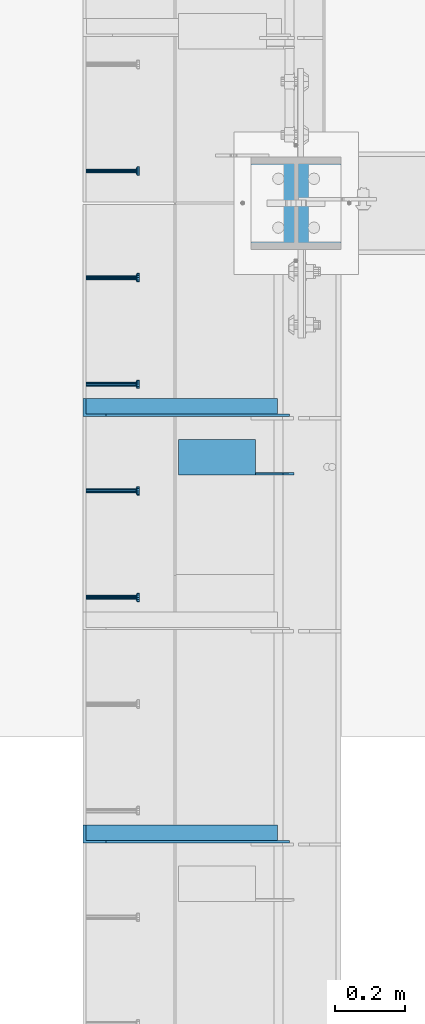
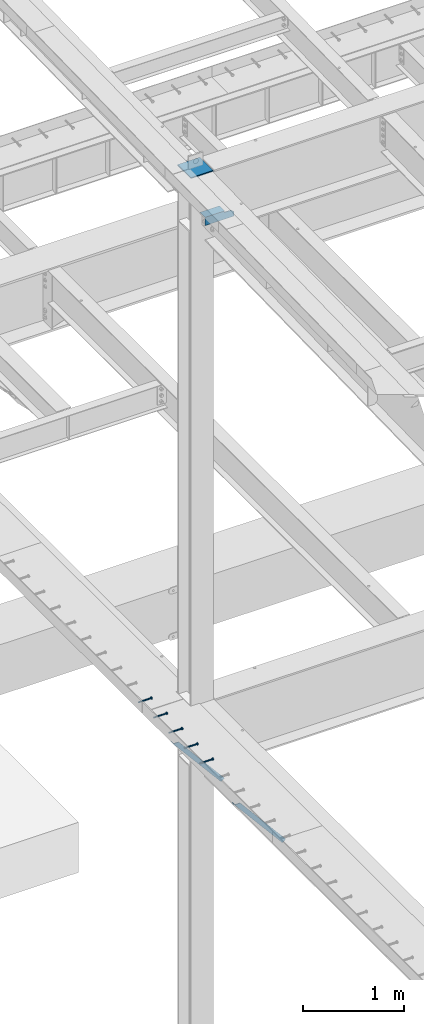
# One storey, part 1280 of 1763: 7 beams, 2 members, 8 elements without a shape of their own.
"""IFC2X3 building model written with IfcOpenShell, lengths in millimetres."""

from ifc_helpers import new_model, si_unit, frame, origin_with_axes, place, context, subcontext, project, spatial, faceted_brep, material, type_object, element, aggregate, save


model = new_model("IFC2X3")

# Units and contexts
model_context = context("Model", 3, precision=1e-05, world=origin_with_axes())
body_context = subcontext(model_context, "Body", "Model", "MODEL_VIEW")
ifc_project = project(units=[si_unit("LENGTHUNIT", "METRE", prefix="MILLI"), si_unit("AREAUNIT", "SQUARE_METRE"), si_unit("VOLUMEUNIT", "CUBIC_METRE"), si_unit("MASSUNIT", "GRAM", prefix="KILO"), si_unit("TIMEUNIT", "SECOND"), si_unit("PLANEANGLEUNIT", "RADIAN"), si_unit("SOLIDANGLEUNIT", "STERADIAN"), si_unit("THERMODYNAMICTEMPERATUREUNIT", "DEGREE_CELSIUS"), si_unit("LUMINOUSINTENSITYUNIT", "LUMEN")], contexts=[model_context])

# Site, building, storey
site_placement = place(None, origin_with_axes())
site = spatial("IfcSite", under=ifc_project, at=site_placement, CompositionType="ELEMENT")
building_placement = place(site_placement, origin_with_axes())
building = spatial("IfcBuilding", under=site, at=building_placement, Name="Undefined", CompositionType="ELEMENT")
storey_placement = place(building_placement, origin_with_axes())
storey = spatial("IfcBuildingStorey", under=building, at=storey_placement, Name="Undefined", CompositionType="ELEMENT", Elevation=0.0)

# Assembly, beam
assembly_1_placement = place(storey_placement, origin_with_axes())
assembly_1 = element("IfcElementAssembly", 1, at=assembly_1_placement, inside=storey, Name="HEADED STUD ANCHOR", AssemblyPlace="NOTDEFINED", PredefinedType="RIGID_FRAME")
ifc_material_1 = material(Name="STEEL/A108")
beam_type_1 = type_object("IfcBeamType", PredefinedType="NOTDEFINED")
beam_1_placement = place(assembly_1_placement, frame((-87975.5122736983, 43678.4750061035, 5268.91250001202), z_axis=(0.0, 0.0, -1.0), x_axis=(1.0, 0.0, 0.0)))
beam_1 = element("IfcBeam", 2, at=beam_1_placement, type_object=beam_type_1, material=ifc_material_1, Name="HEADED STUD ANCHOR", context=body_context, shape_type="Brep", body=[
    faceted_brep([(0.0, -3.1800000667572, 5.5), (0.0, -5.5, 3.1800000667572), (141.732000000002, -5.5, 3.1800000667572), (141.732000000002, -3.1800000667572, 5.5), (0.0, -6.34999999999491, 1.45519152283669e-11), (141.732000000002, -6.34999990463257, 0.0), (0.0, -5.5, -3.1800000667572), (141.732000000002, -5.5, -3.1800000667572), (0.0, -3.1800000667572, -5.5), (141.732000000002, -3.1800000667572, -5.5), (0.0, 0.0, -6.34999990463257), (141.732000000002, 0.0, -6.34999990463257), (0.0, 3.1800000667572, -5.5), (141.732000000002, 3.1800000667572, -5.5), (0.0, 5.5, -3.1800000667572), (141.732000000002, 5.5, -3.1800000667572), (0.0, 6.34999999999491, -2.91038304567337e-11), (141.732000000002, 6.34999990463257, 0.0), (0.0, 5.5, 3.1800000667572), (141.732000000002, 5.5, 3.1800000667572), (0.0, 3.1800000667572, 5.5), (141.732000000002, 3.1800000667572, 5.5), (0.0, 0.0, 6.34999990463257), (141.732000000002, 0.0, 6.34999990463257), (144.780000000001, -10.9899997711182, 6.34999990463257), (144.780000000001, -6.34000015258789, 10.9899997711182), (144.780000000001, -12.6999998092651, 0.0), (144.780000000001, -10.9899997711182, -6.34999990463257), (144.780000000001, -6.34000015258789, -10.9899997711182), (144.780000000001, 0.0, -12.6899995803833), (144.780000000001, 6.34000015258789, -10.9899997711182), (144.780000000001, 10.9899997711182, -6.34999990463257), (144.780000000001, 12.6999998092651, 0.0), (144.780000000001, 10.9899997711182, 6.34999990463257), (144.780000000001, 6.34000015258789, 10.9899997711182), (144.780000000001, 0.0, 12.6899995803833), (152.400000000001, -10.9899997711182, 6.34999990463257), (152.400000000001, -6.34000015258789, 10.9899997711182), (152.400000000001, -12.6999998092651, 0.0), (152.400000000001, -10.9899997711182, -6.34999990463257), (152.400000000001, -6.34000015258789, -10.9899997711182), (152.400000000001, 0.0, -12.6899995803833), (152.400000000001, 6.34000015258789, -10.9899997711182), (152.400000000001, 10.9899997711182, -6.34999990463257), (152.400000000001, 12.6999998092651, 0.0), (152.400000000001, 10.9899997711182, 6.34999990463257), (152.400000000001, 6.34000015258789, 10.9899997711182), (152.400000000001, 0.0, 12.6899995803833)], [[[0, 1, 2, 3]], [[1, 4, 5, 2]], [[4, 6, 7, 5]], [[6, 8, 9, 7]], [[8, 10, 11, 9]], [[10, 12, 13, 11]], [[12, 14, 15, 13]], [[14, 16, 17, 15]], [[16, 18, 19, 17]], [[18, 20, 21, 19]], [[20, 22, 23, 21]], [[22, 0, 3, 23]], [[22, 20, 18, 16, 14, 12, 10, 8, 6, 4, 1, 0]], [[3, 2, 24, 25]], [[2, 5, 26, 24]], [[5, 7, 27, 26]], [[7, 9, 28, 27]], [[9, 11, 29, 28]], [[11, 13, 30, 29]], [[13, 15, 31, 30]], [[15, 17, 32, 31]], [[17, 19, 33, 32]], [[19, 21, 34, 33]], [[21, 23, 35, 34]], [[23, 3, 25, 35]], [[25, 24, 36, 37]], [[24, 26, 38, 36]], [[26, 27, 39, 38]], [[27, 28, 40, 39]], [[28, 29, 41, 40]], [[29, 30, 42, 41]], [[30, 31, 43, 42]], [[31, 32, 44, 43]], [[32, 33, 45, 44]], [[33, 34, 46, 45]], [[34, 35, 47, 46]], [[35, 25, 37, 47]], [[38, 39, 40, 41, 42, 43, 44, 45, 46, 47, 37, 36]]]),
])
aggregate(assembly_1, [beam_1])

assembly_2_placement = place(storey_placement, origin_with_axes())
assembly_2 = element("IfcElementAssembly", 3, at=assembly_2_placement, inside=storey, Name="HEADED STUD ANCHOR", AssemblyPlace="NOTDEFINED", PredefinedType="RIGID_FRAME")
beam_2_placement = place(assembly_2_placement, frame((-87975.5122736983, 43983.2750061035, 5268.91250001202), z_axis=(0.0, 0.0, -1.0), x_axis=(1.0, 0.0, 0.0)))
beam_2 = element("IfcBeam", 4, at=beam_2_placement, type_object=beam_type_1, material=ifc_material_1, Name="HEADED STUD ANCHOR", context=body_context, shape_type="Brep", body=[
    faceted_brep([(0.0, -3.1800000667572, 5.5), (0.0, -5.5, 3.1800000667572), (141.732000000002, -5.5, 3.1800000667572), (141.732000000002, -3.1800000667572, 5.5), (0.0, -6.34999999999491, 1.45519152283669e-11), (141.732000000002, -6.34999990463257, 0.0), (0.0, -5.5, -3.1800000667572), (141.732000000002, -5.5, -3.1800000667572), (0.0, -3.1800000667572, -5.5), (141.732000000002, -3.1800000667572, -5.5), (0.0, 0.0, -6.34999990463257), (141.732000000002, 0.0, -6.34999990463257), (0.0, 3.1800000667572, -5.5), (141.732000000002, 3.1800000667572, -5.5), (0.0, 5.5, -3.1800000667572), (141.732000000002, 5.5, -3.1800000667572), (0.0, 6.34999999999491, -2.91038304567337e-11), (141.732000000002, 6.34999990463257, 0.0), (0.0, 5.5, 3.1800000667572), (141.732000000002, 5.5, 3.1800000667572), (0.0, 3.1800000667572, 5.5), (141.732000000002, 3.1800000667572, 5.5), (0.0, 0.0, 6.34999990463257), (141.732000000002, 0.0, 6.34999990463257), (144.780000000001, -10.9899997711182, 6.34999990463257), (144.780000000001, -6.34000015258789, 10.9899997711182), (144.780000000001, -12.6999998092651, 0.0), (144.780000000001, -10.9899997711182, -6.34999990463257), (144.780000000001, -6.34000015258789, -10.9899997711182), (144.780000000001, 0.0, -12.6899995803833), (144.780000000001, 6.34000015258789, -10.9899997711182), (144.780000000001, 10.9899997711182, -6.34999990463257), (144.780000000001, 12.6999998092651, 0.0), (144.780000000001, 10.9899997711182, 6.34999990463257), (144.780000000001, 6.34000015258789, 10.9899997711182), (144.780000000001, 0.0, 12.6899995803833), (152.400000000001, -10.9899997711182, 6.34999990463257), (152.400000000001, -6.34000015258789, 10.9899997711182), (152.400000000001, -12.6999998092651, 0.0), (152.400000000001, -10.9899997711182, -6.34999990463257), (152.400000000001, -6.34000015258789, -10.9899997711182), (152.400000000001, 0.0, -12.6899995803833), (152.400000000001, 6.34000015258789, -10.9899997711182), (152.400000000001, 10.9899997711182, -6.34999990463257), (152.400000000001, 12.6999998092651, 0.0), (152.400000000001, 10.9899997711182, 6.34999990463257), (152.400000000001, 6.34000015258789, 10.9899997711182), (152.400000000001, 0.0, 12.6899995803833)], [[[0, 1, 2, 3]], [[1, 4, 5, 2]], [[4, 6, 7, 5]], [[6, 8, 9, 7]], [[8, 10, 11, 9]], [[10, 12, 13, 11]], [[12, 14, 15, 13]], [[14, 16, 17, 15]], [[16, 18, 19, 17]], [[18, 20, 21, 19]], [[20, 22, 23, 21]], [[22, 0, 3, 23]], [[22, 20, 18, 16, 14, 12, 10, 8, 6, 4, 1, 0]], [[3, 2, 24, 25]], [[2, 5, 26, 24]], [[5, 7, 27, 26]], [[7, 9, 28, 27]], [[9, 11, 29, 28]], [[11, 13, 30, 29]], [[13, 15, 31, 30]], [[15, 17, 32, 31]], [[17, 19, 33, 32]], [[19, 21, 34, 33]], [[21, 23, 35, 34]], [[23, 3, 25, 35]], [[25, 24, 36, 37]], [[24, 26, 38, 36]], [[26, 27, 39, 38]], [[27, 28, 40, 39]], [[28, 29, 41, 40]], [[29, 30, 42, 41]], [[30, 31, 43, 42]], [[31, 32, 44, 43]], [[32, 33, 45, 44]], [[33, 34, 46, 45]], [[34, 35, 47, 46]], [[35, 25, 37, 47]], [[38, 39, 40, 41, 42, 43, 44, 45, 46, 47, 37, 36]]]),
])
aggregate(assembly_2, [beam_2])

assembly_3_placement = place(storey_placement, origin_with_axes())
assembly_3 = element("IfcElementAssembly", 5, at=assembly_3_placement, inside=storey, Name="HEADED STUD ANCHOR", AssemblyPlace="NOTDEFINED", PredefinedType="RIGID_FRAME")
beam_3_placement = place(assembly_3_placement, frame((-87975.5122736983, 44288.0750061035, 5268.91250001202), z_axis=(0.0, 0.0, -1.0), x_axis=(1.0, 0.0, 0.0)))
beam_3 = element("IfcBeam", 6, at=beam_3_placement, type_object=beam_type_1, material=ifc_material_1, Name="HEADED STUD ANCHOR", context=body_context, shape_type="Brep", body=[
    faceted_brep([(0.0, -3.1800000667572, 5.5), (0.0, -5.5, 3.1800000667572), (141.732000000002, -5.5, 3.1800000667572), (141.732000000002, -3.1800000667572, 5.5), (0.0, -6.34999999999491, 1.45519152283669e-11), (141.732000000002, -6.34999990463257, 0.0), (0.0, -5.5, -3.1800000667572), (141.732000000002, -5.5, -3.1800000667572), (0.0, -3.1800000667572, -5.5), (141.732000000002, -3.1800000667572, -5.5), (0.0, 0.0, -6.34999990463257), (141.732000000002, 0.0, -6.34999990463257), (0.0, 3.1800000667572, -5.5), (141.732000000002, 3.1800000667572, -5.5), (0.0, 5.5, -3.1800000667572), (141.732000000002, 5.5, -3.1800000667572), (0.0, 6.34999999999491, -2.91038304567337e-11), (141.732000000002, 6.34999990463257, 0.0), (0.0, 5.5, 3.1800000667572), (141.732000000002, 5.5, 3.1800000667572), (0.0, 3.1800000667572, 5.5), (141.732000000002, 3.1800000667572, 5.5), (0.0, 0.0, 6.34999990463257), (141.732000000002, 0.0, 6.34999990463257), (144.780000000001, -10.9899997711182, 6.34999990463257), (144.780000000001, -6.34000015258789, 10.9899997711182), (144.780000000001, -12.6999998092651, 0.0), (144.780000000001, -10.9899997711182, -6.34999990463257), (144.780000000001, -6.34000015258789, -10.9899997711182), (144.780000000001, 0.0, -12.6899995803833), (144.780000000001, 6.34000015258789, -10.9899997711182), (144.780000000001, 10.9899997711182, -6.34999990463257), (144.780000000001, 12.6999998092651, 0.0), (144.780000000001, 10.9899997711182, 6.34999990463257), (144.780000000001, 6.34000015258789, 10.9899997711182), (144.780000000001, 0.0, 12.6899995803833), (152.400000000001, -10.9899997711182, 6.34999990463257), (152.400000000001, -6.34000015258789, 10.9899997711182), (152.400000000001, -12.6999998092651, 0.0), (152.400000000001, -10.9899997711182, -6.34999990463257), (152.400000000001, -6.34000015258789, -10.9899997711182), (152.400000000001, 0.0, -12.6899995803833), (152.400000000001, 6.34000015258789, -10.9899997711182), (152.400000000001, 10.9899997711182, -6.34999990463257), (152.400000000001, 12.6999998092651, 0.0), (152.400000000001, 10.9899997711182, 6.34999990463257), (152.400000000001, 6.34000015258789, 10.9899997711182), (152.400000000001, 0.0, 12.6899995803833)], [[[0, 1, 2, 3]], [[1, 4, 5, 2]], [[4, 6, 7, 5]], [[6, 8, 9, 7]], [[8, 10, 11, 9]], [[10, 12, 13, 11]], [[12, 14, 15, 13]], [[14, 16, 17, 15]], [[16, 18, 19, 17]], [[18, 20, 21, 19]], [[20, 22, 23, 21]], [[22, 0, 3, 23]], [[22, 20, 18, 16, 14, 12, 10, 8, 6, 4, 1, 0]], [[3, 2, 24, 25]], [[2, 5, 26, 24]], [[5, 7, 27, 26]], [[7, 9, 28, 27]], [[9, 11, 29, 28]], [[11, 13, 30, 29]], [[13, 15, 31, 30]], [[15, 17, 32, 31]], [[17, 19, 33, 32]], [[19, 21, 34, 33]], [[21, 23, 35, 34]], [[23, 3, 25, 35]], [[25, 24, 36, 37]], [[24, 26, 38, 36]], [[26, 27, 39, 38]], [[27, 28, 40, 39]], [[28, 29, 41, 40]], [[29, 30, 42, 41]], [[30, 31, 43, 42]], [[31, 32, 44, 43]], [[32, 33, 45, 44]], [[33, 34, 46, 45]], [[34, 35, 47, 46]], [[35, 25, 37, 47]], [[38, 39, 40, 41, 42, 43, 44, 45, 46, 47, 37, 36]]]),
])
aggregate(assembly_3, [beam_3])

assembly_4_placement = place(storey_placement, origin_with_axes())
assembly_4 = element("IfcElementAssembly", 7, at=assembly_4_placement, inside=storey, Name="HEADED STUD ANCHOR", AssemblyPlace="NOTDEFINED", PredefinedType="RIGID_FRAME")
beam_4_placement = place(assembly_4_placement, frame((-87975.5122736983, 44592.8750061035, 5268.91250001202), z_axis=(0.0, 0.0, -1.0), x_axis=(1.0, 0.0, 0.0)))
beam_4 = element("IfcBeam", 8, at=beam_4_placement, type_object=beam_type_1, material=ifc_material_1, Name="HEADED STUD ANCHOR", context=body_context, shape_type="Brep", body=[
    faceted_brep([(0.0, -3.1800000667572, 5.5), (0.0, -5.5, 3.1800000667572), (141.732000000002, -5.5, 3.1800000667572), (141.732000000002, -3.1800000667572, 5.5), (0.0, -6.34999999999491, 1.45519152283669e-11), (141.732000000002, -6.34999990463257, 0.0), (0.0, -5.5, -3.1800000667572), (141.732000000002, -5.5, -3.1800000667572), (0.0, -3.1800000667572, -5.5), (141.732000000002, -3.1800000667572, -5.5), (0.0, 0.0, -6.34999990463257), (141.732000000002, 0.0, -6.34999990463257), (0.0, 3.1800000667572, -5.5), (141.732000000002, 3.1800000667572, -5.5), (0.0, 5.5, -3.1800000667572), (141.732000000002, 5.5, -3.1800000667572), (0.0, 6.34999999999491, -2.91038304567337e-11), (141.732000000002, 6.34999990463257, 0.0), (0.0, 5.5, 3.1800000667572), (141.732000000002, 5.5, 3.1800000667572), (0.0, 3.1800000667572, 5.5), (141.732000000002, 3.1800000667572, 5.5), (0.0, 0.0, 6.34999990463257), (141.732000000002, 0.0, 6.34999990463257), (144.780000000001, -10.9899997711182, 6.34999990463257), (144.780000000001, -6.34000015258789, 10.9899997711182), (144.780000000001, -12.6999998092651, 0.0), (144.780000000001, -10.9899997711182, -6.34999990463257), (144.780000000001, -6.34000015258789, -10.9899997711182), (144.780000000001, 0.0, -12.6899995803833), (144.780000000001, 6.34000015258789, -10.9899997711182), (144.780000000001, 10.9899997711182, -6.34999990463257), (144.780000000001, 12.6999998092651, 0.0), (144.780000000001, 10.9899997711182, 6.34999990463257), (144.780000000001, 6.34000015258789, 10.9899997711182), (144.780000000001, 0.0, 12.6899995803833), (152.400000000001, -10.9899997711182, 6.34999990463257), (152.400000000001, -6.34000015258789, 10.9899997711182), (152.400000000001, -12.6999998092651, 0.0), (152.400000000001, -10.9899997711182, -6.34999990463257), (152.400000000001, -6.34000015258789, -10.9899997711182), (152.400000000001, 0.0, -12.6899995803833), (152.400000000001, 6.34000015258789, -10.9899997711182), (152.400000000001, 10.9899997711182, -6.34999990463257), (152.400000000001, 12.6999998092651, 0.0), (152.400000000001, 10.9899997711182, 6.34999990463257), (152.400000000001, 6.34000015258789, 10.9899997711182), (152.400000000001, 0.0, 12.6899995803833)], [[[0, 1, 2, 3]], [[1, 4, 5, 2]], [[4, 6, 7, 5]], [[6, 8, 9, 7]], [[8, 10, 11, 9]], [[10, 12, 13, 11]], [[12, 14, 15, 13]], [[14, 16, 17, 15]], [[16, 18, 19, 17]], [[18, 20, 21, 19]], [[20, 22, 23, 21]], [[22, 0, 3, 23]], [[22, 20, 18, 16, 14, 12, 10, 8, 6, 4, 1, 0]], [[3, 2, 24, 25]], [[2, 5, 26, 24]], [[5, 7, 27, 26]], [[7, 9, 28, 27]], [[9, 11, 29, 28]], [[11, 13, 30, 29]], [[13, 15, 31, 30]], [[15, 17, 32, 31]], [[17, 19, 33, 32]], [[19, 21, 34, 33]], [[21, 23, 35, 34]], [[23, 3, 25, 35]], [[25, 24, 36, 37]], [[24, 26, 38, 36]], [[26, 27, 39, 38]], [[27, 28, 40, 39]], [[28, 29, 41, 40]], [[29, 30, 42, 41]], [[30, 31, 43, 42]], [[31, 32, 44, 43]], [[32, 33, 45, 44]], [[33, 34, 46, 45]], [[34, 35, 47, 46]], [[35, 25, 37, 47]], [[38, 39, 40, 41, 42, 43, 44, 45, 46, 47, 37, 36]]]),
])
aggregate(assembly_4, [beam_4])

assembly_5_placement = place(storey_placement, origin_with_axes())
assembly_5 = element("IfcElementAssembly", 9, at=assembly_5_placement, inside=storey, Name="HEADED STUD ANCHOR", AssemblyPlace="NOTDEFINED", PredefinedType="RIGID_FRAME")
beam_5_placement = place(assembly_5_placement, frame((-87975.5122736983, 44897.6750061035, 5268.91250001202), z_axis=(0.0, 0.0, -1.0), x_axis=(1.0, 0.0, 0.0)))
beam_5 = element("IfcBeam", 10, at=beam_5_placement, type_object=beam_type_1, material=ifc_material_1, Name="HEADED STUD ANCHOR", context=body_context, shape_type="Brep", body=[
    faceted_brep([(0.0, -3.1800000667572, 5.5), (0.0, -5.5, 3.1800000667572), (141.732000000002, -5.5, 3.1800000667572), (141.732000000002, -3.1800000667572, 5.5), (0.0, -6.34999999999491, 1.45519152283669e-11), (141.732000000002, -6.34999990463257, 0.0), (0.0, -5.5, -3.1800000667572), (141.732000000002, -5.5, -3.1800000667572), (0.0, -3.1800000667572, -5.5), (141.732000000002, -3.1800000667572, -5.5), (0.0, 0.0, -6.34999990463257), (141.732000000002, 0.0, -6.34999990463257), (0.0, 3.1800000667572, -5.5), (141.732000000002, 3.1800000667572, -5.5), (0.0, 5.5, -3.1800000667572), (141.732000000002, 5.5, -3.1800000667572), (0.0, 6.34999999999491, -2.91038304567337e-11), (141.732000000002, 6.34999990463257, 0.0), (0.0, 5.5, 3.1800000667572), (141.732000000002, 5.5, 3.1800000667572), (0.0, 3.1800000667572, 5.5), (141.732000000002, 3.1800000667572, 5.5), (0.0, 0.0, 6.34999990463257), (141.732000000002, 0.0, 6.34999990463257), (144.780000000001, -10.9899997711182, 6.34999990463257), (144.780000000001, -6.34000015258789, 10.9899997711182), (144.780000000001, -12.6999998092651, 0.0), (144.780000000001, -10.9899997711182, -6.34999990463257), (144.780000000001, -6.34000015258789, -10.9899997711182), (144.780000000001, 0.0, -12.6899995803833), (144.780000000001, 6.34000015258789, -10.9899997711182), (144.780000000001, 10.9899997711182, -6.34999990463257), (144.780000000001, 12.6999998092651, 0.0), (144.780000000001, 10.9899997711182, 6.34999990463257), (144.780000000001, 6.34000015258789, 10.9899997711182), (144.780000000001, 0.0, 12.6899995803833), (152.400000000001, -10.9899997711182, 6.34999990463257), (152.400000000001, -6.34000015258789, 10.9899997711182), (152.400000000001, -12.6999998092651, 0.0), (152.400000000001, -10.9899997711182, -6.34999990463257), (152.400000000001, -6.34000015258789, -10.9899997711182), (152.400000000001, 0.0, -12.6899995803833), (152.400000000001, 6.34000015258789, -10.9899997711182), (152.400000000001, 10.9899997711182, -6.34999990463257), (152.400000000001, 12.6999998092651, 0.0), (152.400000000001, 10.9899997711182, 6.34999990463257), (152.400000000001, 6.34000015258789, 10.9899997711182), (152.400000000001, 0.0, 12.6899995803833)], [[[0, 1, 2, 3]], [[1, 4, 5, 2]], [[4, 6, 7, 5]], [[6, 8, 9, 7]], [[8, 10, 11, 9]], [[10, 12, 13, 11]], [[12, 14, 15, 13]], [[14, 16, 17, 15]], [[16, 18, 19, 17]], [[18, 20, 21, 19]], [[20, 22, 23, 21]], [[22, 0, 3, 23]], [[22, 20, 18, 16, 14, 12, 10, 8, 6, 4, 1, 0]], [[3, 2, 24, 25]], [[2, 5, 26, 24]], [[5, 7, 27, 26]], [[7, 9, 28, 27]], [[9, 11, 29, 28]], [[11, 13, 30, 29]], [[13, 15, 31, 30]], [[15, 17, 32, 31]], [[17, 19, 33, 32]], [[19, 21, 34, 33]], [[21, 23, 35, 34]], [[23, 3, 25, 35]], [[25, 24, 36, 37]], [[24, 26, 38, 36]], [[26, 27, 39, 38]], [[27, 28, 40, 39]], [[28, 29, 41, 40]], [[29, 30, 42, 41]], [[30, 31, 43, 42]], [[31, 32, 44, 43]], [[32, 33, 45, 44]], [[33, 34, 46, 45]], [[34, 35, 47, 46]], [[35, 25, 37, 47]], [[38, 39, 40, 41, 42, 43, 44, 45, 46, 47, 37, 36]]]),
])
aggregate(assembly_5, [beam_5])

# Assembly, members
assembly_6_placement = place(storey_placement, origin_with_axes())
assembly_6 = element("IfcElementAssembly", 11, at=assembly_6_placement, inside=storey, Name="BEAM", AssemblyPlace="NOTDEFINED", PredefinedType="RIGID_FRAME")
ifc_material_2 = material(Name="STEEL/A36")
member_type = type_object("IfcMemberType", Name="L2X2X1/4", PredefinedType="NOTDEFINED")
member_1_placement = place(assembly_6_placement, frame((-87414.1929584935, 43002.2, 4557.35349338836), z_axis=(0.764183480307171, 0.0, 0.644998921259268), x_axis=(-0.644998921259266, 0.0, 0.764183480307173)))
member_1 = element("IfcMember", 12, at=member_1_placement, type_object=member_type, material=ifc_material_2, Name="ANGLE", ObjectType="L2X2X1/4", context=body_context, shape_type="Brep", body=[
    faceted_brep([(-1.45519152283669e-11, 25.4000000000015, -25.3999999999869), (1.45519152283669e-11, 25.4000000000015, 25.3999999999796), (812.060911532491, 25.4000000000015, 25.400000001966), (854.937976763787, 25.4000000000015, -25.3999999979424), (1.45519152283669e-11, 19.0499999999993, 25.3999999999796), (812.060911532491, 19.0500000000029, 25.400000001966), (-7.27595761418343e-12, 19.0499999999993, -19.0499999999956), (849.578343609872, 19.0500000000029, -19.0499999979511), (-7.27595761418343e-12, -25.4000000000015, -19.0499999999956), (849.578343609872, -25.4000000000015, -19.0499999979511), (-1.45519152283669e-11, -25.4000000000015, -25.3999999999869), (854.937976763787, -25.4000000000015, -25.3999999979424)], [[[0, 1, 2, 3]], [[1, 4, 5, 2]], [[4, 6, 7, 5]], [[6, 8, 9, 7]], [[8, 10, 11, 9]], [[10, 0, 3, 11]], [[5, 7, 9, 11, 3, 2]], [[10, 8, 6, 4, 1, 0]]]),
])
member_2_placement = place(assembly_6_placement, frame((-87414.1929584935, 44221.4, 4557.35349338836), z_axis=(0.764183480307171, 0.0, 0.644998921259268), x_axis=(-0.644998921259266, 0.0, 0.764183480307173)))
member_2 = element("IfcMember", 13, at=member_2_placement, type_object=member_type, material=ifc_material_2, Name="ANGLE", ObjectType="L2X2X1/4", context=body_context, shape_type="Brep", body=[
    faceted_brep([(-1.45519152283669e-11, 25.4000000000015, -25.3999999999869), (1.45519152283669e-11, 25.4000000000015, 25.3999999999796), (812.060911532491, 25.4000000000015, 25.400000001966), (854.937976763787, 25.4000000000015, -25.3999999979424), (1.45519152283669e-11, 19.0499999999993, 25.3999999999796), (812.060911532491, 19.0500000000029, 25.400000001966), (-7.27595761418343e-12, 19.0499999999993, -19.0499999999956), (849.578343609872, 19.0500000000029, -19.0499999979511), (-7.27595761418343e-12, -25.4000000000015, -19.0499999999956), (849.578343609872, -25.4000000000015, -19.0499999979511), (-1.45519152283669e-11, -25.4000000000015, -25.3999999999869), (854.937976763787, -25.4000000000015, -25.3999999979424)], [[[0, 1, 2, 3]], [[1, 4, 5, 2]], [[4, 6, 7, 5]], [[6, 8, 9, 7]], [[8, 10, 11, 9]], [[10, 0, 3, 11]], [[5, 7, 9, 11, 3, 2]], [[10, 8, 6, 4, 1, 0]]]),
])
aggregate(assembly_6, [member_1, member_2])

# Assembly, beam
assembly_7_placement = place(storey_placement, origin_with_axes())
assembly_7 = element("IfcElementAssembly", 14, at=assembly_7_placement, inside=storey, Name="BEAM", AssemblyPlace="NOTDEFINED", PredefinedType="RIGID_FRAME")
beam_type_2 = type_object("IfcBeamType", Name="L4X4X1/4", PredefinedType="NOTDEFINED")
beam_6_placement = place(assembly_7_placement, frame((-87711.9872706466, 44079.767679509, 11530.3229372075), z_axis=(0.0, 0.0206852279954837, -0.999786037781472), x_axis=(1.0, 0.0, 0.0)))
beam_6 = element("IfcBeam", 15, at=beam_6_placement, type_object=beam_type_2, material=ifc_material_2, Name="BRACE", ObjectType="L4X4X1/4", context=body_context, shape_type="Brep", body=[
    faceted_brep([(330.993730570859, 44.4500000001281, -1.58750213774329), (299.243734988457, 44.4500000001208, -33.3493444566793), (299.243734988457, 50.8000000001339, -33.3493444612141), (330.993746948254, 50.8000000001412, -1.5875021377451), (1.96450855582952e-10, -50.8000000000338, -44.4499999999534), (2.11002770811319e-10, -50.8000000000357, -50.799999999952), (220.66276795695, -50.800000000163, -50.7999999999502), (220.662761962012, -50.800000000163, -44.4499999999553), (-3.63797880709171e-11, 50.8000000000011, -50.8000000000538), (220.662767915564, 50.8000000001339, -50.7999999999774), (220.662761923406, 44.4500000001208, -44.4499999999807), (220.662751535681, 50.8000000001339, -33.3786578752915), (220.662751538272, 44.4500000001208, -33.3786578752897), (-2.18278728425503e-11, 44.4500000000007, -44.450000000048), (-1.81898940354586e-10, 44.4500000000371, 50.7999999999374), (-1.96450855582952e-10, 50.8000000000393, 50.7999999999374), (330.993731689443, 44.4500000000007, 50.7999999999993), (330.993731689443, 50.7999999999993, 50.7999999999993)], [[[0, 1, 2, 3]], [[4, 5, 6, 7]], [[5, 8, 9, 6]], [[10, 7, 6, 9, 11, 12]], [[13, 4, 7, 10]], [[5, 4, 13, 14, 15, 8]], [[15, 14, 16, 17]], [[17, 16, 0, 3]], [[11, 9, 8, 15, 17, 3, 2]], [[12, 11, 2, 1]], [[16, 14, 13, 10, 12, 1, 0]]]),
])
aggregate(assembly_7, [beam_6])

assembly_8_placement = place(storey_placement, origin_with_axes())
assembly_8 = element("IfcElementAssembly", 16, at=assembly_8_placement, inside=storey, Name="COLUMN", AssemblyPlace="NOTDEFINED", PredefinedType="RIGID_FRAME")
beam_type_3 = type_object("IfcBeamType", PredefinedType="NOTDEFINED")
beam_7_placement = place(assembly_8_placement, frame((-87375.4372736983, 44673.8375, 11589.345312), z_axis=(1.0, 0.0, 0.0), x_axis=(0.0, 1.0, 0.0)))
beam_7 = element("IfcBeam", 17, at=beam_7_placement, type_object=beam_type_3, material=ifc_material_2, Name="PLATE", context=body_context, shape_type="Brep", body=[
    faceted_brep([(0.0, 6.35000000000036, -128.587500000001), (0.0, 6.35000000000036, 128.587500000001), (263.525000000001, 6.35000000000036, 128.587500000001), (263.525000000001, 6.35000000000036, -128.587500000001), (0.0, -6.35000000000036, 128.587500000001), (263.525000000001, -6.35000000000036, 128.587500000001), (0.0, -6.35000000000036, -128.587500000001), (263.525000000001, -6.35000000000036, -128.587500000001)], [[[0, 1, 2, 3]], [[1, 4, 5, 2]], [[4, 6, 7, 5]], [[6, 0, 3, 7]], [[5, 7, 3, 2]], [[6, 4, 1, 0]]]),
])
aggregate(assembly_8, [beam_7])

save(model, "model.ifc")
